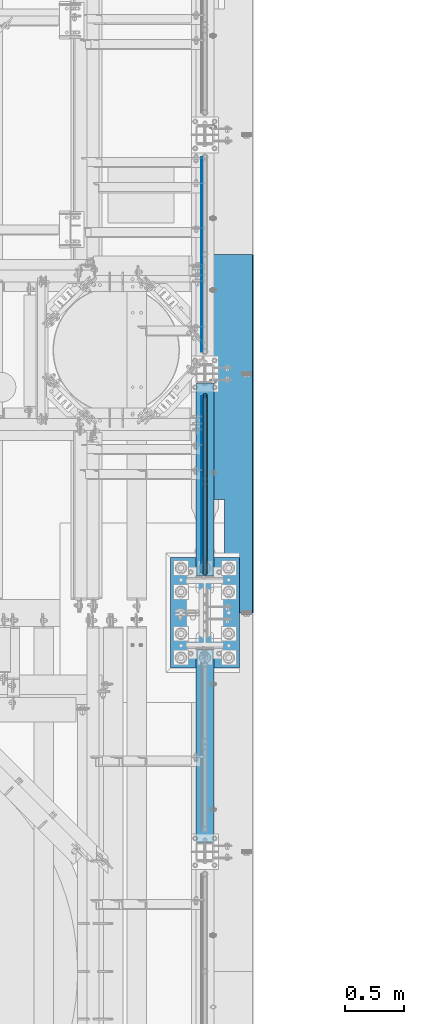
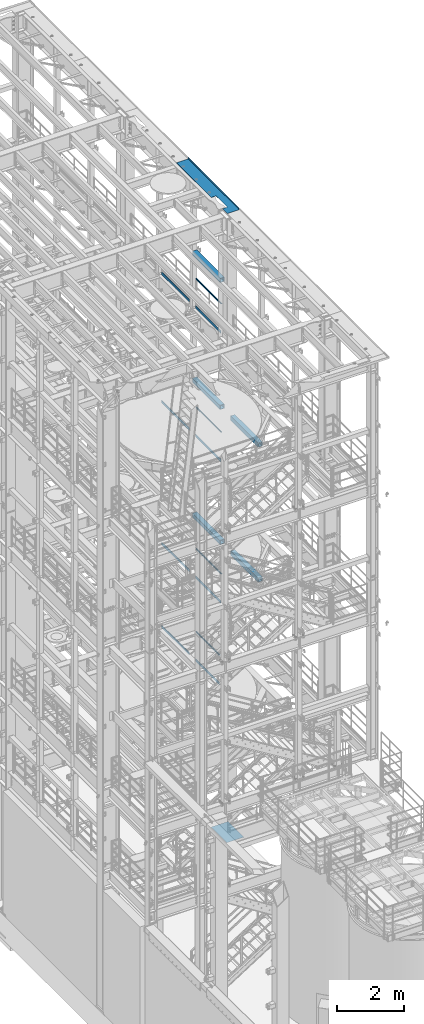
# One storey, part 1036 of 1876: 19 beams, 15 elements without a shape of their own.
"""IFC2X3 building model written with IfcOpenShell, lengths in millimetres."""

import ifcopenshell
import ifcopenshell.guid

model = None  # the IFC model being written
_history = None  # IfcOwnerHistory: only IFC2X3 demands one
_inside = {}  # id of a spatial element -> (the spatial element, [elements in it])
_under = {}  # id of a project, library or spatial element -> (it, [spatial elements below it])
_declared = {}  # id of a project -> (the project, [libraries it declares])
_typed = {}  # id of a type object -> (the type object, [elements of that type])
_made_of = {}  # id of a material, layer set ... -> (it, [elements and type objects made of it])


def new_model(schema):
    """Start an empty IFC model of exactly this schema.

    Asked for "IFC4X3", IfcOpenShell would pick the latest addendum, in which some entities
    have other attributes; the version numbers below select the first issue.
    IFC2X3 requires an IfcOwnerHistory on every rooted entity: one is made here for all.
    """
    global model, _history
    if schema == "IFC4X3":
        model = ifcopenshell.file(schema_version=(4, 3, 0, 0))
    else:
        model = ifcopenshell.file(schema=schema)
    _inside.clear()
    _under.clear()
    _declared.clear()
    _typed.clear()
    _made_of.clear()
    _history = None
    if model.schema == "IFC2X3":
        org = make("IfcOrganization", Name="unknown")
        user = make(
            "IfcPersonAndOrganization",
            ThePerson=make("IfcPerson", FamilyName="unknown"),
            TheOrganization=org,
        )
        app = make(
            "IfcApplication",
            ApplicationDeveloper=org,
            Version="unknown",
            ApplicationFullName="unknown",
            ApplicationIdentifier="unknown",
        )
        _history = make(
            "IfcOwnerHistory",
            OwningUser=user,
            OwningApplication=app,
            ChangeAction="ADDED",
            CreationDate=0,
        )
    return model


def make(cls, **values):
    """One entity of the class cls with the attributes given. An attribute that is None is left unset."""
    return model.create_entity(
        cls, **{name: value for name, value in values.items() if value is not None}
    )


def rooted(cls, **values):
    """An entity with a GlobalId (a new one), such as an element, a storey or a relation."""
    return make(cls, GlobalId=ifcopenshell.guid.new(), OwnerHistory=_history, **values)


def si_unit(unit_type, name, prefix=None):
    """IfcSIUnit, for example si_unit("LENGTHUNIT", "METRE", prefix="MILLI")."""
    return make("IfcSIUnit", UnitType=unit_type, Prefix=prefix, Name=name)


def assignment(units):
    """IfcUnitAssignment: the units of a project."""
    return None if units is None else make("IfcUnitAssignment", Units=units)


def point(xyz):
    """IfcCartesianPoint."""
    return None if xyz is None else make("IfcCartesianPoint", Coordinates=xyz)


def direction(xyz):
    """IfcDirection."""
    return None if xyz is None else make("IfcDirection", DirectionRatios=xyz)


def frame(location, z_axis=None, x_axis=None):
    """IfcAxis2Placement3D, a coordinate frame: its origin and axes. An axis left out is left unset."""
    return make(
        "IfcAxis2Placement3D",
        Location=point(location),
        Axis=direction(z_axis),
        RefDirection=direction(x_axis),
    )


def origin_with_axes():
    """The frame at (0, 0, 0) with the z axis (0, 0, 1) and the x axis (1, 0, 0) written out."""
    return frame((0.0, 0.0, 0.0), z_axis=(0.0, 0.0, 1.0), x_axis=(1.0, 0.0, 0.0))


def place(relative_to, where):
    """IfcLocalPlacement: puts the frame where relative to a parent placement (None: the world)."""
    return make(
        "IfcLocalPlacement", PlacementRelTo=relative_to, RelativePlacement=where
    )


def context(
    kind, dimensions, precision=None, world=None, true_north=None, identifier=None
):
    """IfcGeometricRepresentationContext, for example the 3D "Model" context."""
    return make(
        "IfcGeometricRepresentationContext",
        ContextIdentifier=identifier,
        ContextType=kind,
        CoordinateSpaceDimension=dimensions,
        Precision=precision,
        WorldCoordinateSystem=world,
        TrueNorth=true_north,
    )


def subcontext(parent, identifier, kind, view, scale=None):
    """IfcGeometricRepresentationSubContext, for example "Body" below "Model"."""
    return make(
        "IfcGeometricRepresentationSubContext",
        ContextIdentifier=identifier,
        ContextType=kind,
        ParentContext=parent,
        TargetScale=scale,
        TargetView=view,
    )


def project(units=None, contexts=None):
    """IfcProject with its units and contexts."""
    return rooted(
        "IfcProject",
        Name="project",
        RepresentationContexts=contexts,
        UnitsInContext=assignment(units),
    )


def spatial(cls, under=None, at=None, **own):
    """A site, building, storey or space (cls), placed at a placement, below another one or the project."""
    s = rooted(cls, ObjectPlacement=at, **own)
    if under is not None:
        _under.setdefault(under.id(), (under, []))[1].append(s)
    return s


def faces_of(points, faces, orient=None, outer=None):
    """IfcFace entities. A face is a list of loops; a loop is a list of indices into points, from 0.

    orient and outer hold one flag for each loop. By default every Orientation is true, the
    first loop of a face is its IfcFaceOuterBound and the others are IfcFaceBound.
    """
    made = []
    for i, loops in enumerate(faces):
        bounds = []
        for j, loop in enumerate(loops):
            is_outer = j == 0 if outer is None else outer[i][j]
            bounds.append(
                make(
                    "IfcFaceOuterBound" if is_outer else "IfcFaceBound",
                    Bound=make("IfcPolyLoop", Polygon=[points[k] for k in loop]),
                    Orientation=True if orient is None else orient[i][j],
                )
            )
        made.append(make("IfcFace", Bounds=bounds))
    return made


def faceted_brep(points, faces, orient=None, outer=None, voids=None):
    """IfcFacetedBrep: a solid bounded by flat faces; with voids (closed shells), ...WithVoids."""
    shared = [point(p) for p in points]
    hull = make("IfcClosedShell", CfsFaces=faces_of(shared, faces, orient, outer))
    if voids is None:
        return make("IfcFacetedBrep", Outer=hull)
    return make(
        "IfcFacetedBrepWithVoids",
        Outer=hull,
        Voids=[
            make(cls, CfsFaces=faces_of(shared, fs, o, b)) for cls, fs, o, b in voids
        ],
    )


def shape(context_of_items, identifier, shape_type, items):
    """IfcShapeRepresentation: the items that make up one representation, for example the "Body"."""
    return make(
        "IfcShapeRepresentation",
        ContextOfItems=context_of_items,
        RepresentationIdentifier=identifier,
        RepresentationType=shape_type,
        Items=items,
    )


def material(Name=None, Category=None):
    """IfcMaterial."""
    return make("IfcMaterial", Name=Name, Category=Category)


def made_of(thing, what):
    """Note that an element or type object is made of a material, layer set ...; save() writes the relation."""
    if what is not None:
        _made_of.setdefault(what.id(), (what, []))[1].append(thing)
    return thing


def type_object(cls, material=None, **own):
    """A type object (cls), such as IfcWallType, which elements share."""
    return made_of(rooted(cls, **own), material)


def element(
    cls,
    number,
    at=None,
    inside=None,
    cuts=None,
    type_object=None,
    material=None,
    context=None,
    identifier="Body",
    shape_type=None,
    held_by="IfcProductDefinitionShape",
    body=None,
    shapes=None,
    **own,
):
    """One element of the class cls, such as IfcWall. Its Tag is "e" and its number.

    at: its placement. inside: the storey or other place that contains it. cuts: it is an
    opening in that element (IfcRelVoidsElement). A single representation is given by context,
    identifier, shape_type and body (its items); several are given by shapes. held_by: the class
    of the entity that holds the representations. save() writes the other relations.
    """
    e = rooted(cls, Tag="e%d" % number, ObjectPlacement=at, **own)
    if body is not None:
        shapes = [shape(context, identifier, shape_type, body)]
    if shapes is not None:
        e.Representation = make(held_by, Representations=shapes)
    if inside is not None:
        _inside.setdefault(inside.id(), (inside, []))[1].append(e)
    if cuts is not None:
        rooted(
            "IfcRelVoidsElement", RelatingBuildingElement=cuts, RelatedOpeningElement=e
        )
    if type_object is not None:
        _typed.setdefault(type_object.id(), (type_object, []))[1].append(e)
    return made_of(e, material)


def aggregate(whole, parts):
    """IfcRelAggregates: a whole, such as a stair, and the parts it consists of."""
    return rooted("IfcRelAggregates", RelatingObject=whole, RelatedObjects=parts)


def save(model, path):
    """Write the relations noted so far, then the file.

    IfcRelAggregates (storeys below a building ...), IfcRelContainedInSpatialStructure (elements
    in a storey), IfcRelDefinesByType, IfcRelAssociatesMaterial and IfcRelDeclares: one each for
    every whole, place, type object, material and project.
    """
    for whole, parts in _under.values():
        aggregate(whole, parts)
    for where, things in _inside.values():
        rooted(
            "IfcRelContainedInSpatialStructure",
            RelatedElements=things,
            RelatingStructure=where,
        )
    for kind, things in _typed.values():
        rooted("IfcRelDefinesByType", RelatedObjects=things, RelatingType=kind)
    for what, things in _made_of.values():
        rooted("IfcRelAssociatesMaterial", RelatedObjects=things, RelatingMaterial=what)
    for by, libraries in _declared.values():
        rooted("IfcRelDeclares", RelatingContext=by, RelatedDefinitions=libraries)
    model.write(path)


model = new_model("IFC2X3")

# Units and contexts
model_context = context("Model", 3, precision=1e-05, world=origin_with_axes())
body_context = subcontext(model_context, "Body", "Model", "MODEL_VIEW")
ifc_project = project(units=[si_unit("LENGTHUNIT", "METRE", prefix="MILLI"), si_unit("AREAUNIT", "SQUARE_METRE"), si_unit("VOLUMEUNIT", "CUBIC_METRE"), si_unit("MASSUNIT", "GRAM", prefix="KILO"), si_unit("TIMEUNIT", "SECOND"), si_unit("PLANEANGLEUNIT", "RADIAN"), si_unit("SOLIDANGLEUNIT", "STERADIAN"), si_unit("THERMODYNAMICTEMPERATUREUNIT", "DEGREE_CELSIUS"), si_unit("LUMINOUSINTENSITYUNIT", "LUMEN")], contexts=[model_context])

# Site, building, storey
site_placement = place(None, origin_with_axes())
site = spatial("IfcSite", under=ifc_project, at=site_placement, CompositionType="ELEMENT")
building_placement = place(site_placement, origin_with_axes())
building = spatial("IfcBuilding", under=site, at=building_placement, Name="Undefined", CompositionType="ELEMENT")
storey_placement = place(building_placement, origin_with_axes())
storey = spatial("IfcBuildingStorey", under=building, at=storey_placement, Name="Undefined", CompositionType="ELEMENT", Elevation=0.0)

# Assembly, beam
assembly_1_placement = place(storey_placement, origin_with_axes())
assembly_1 = element("IfcElementAssembly", 1, at=assembly_1_placement, inside=storey, Name="RAIL", AssemblyPlace="NOTDEFINED", PredefinedType="RIGID_FRAME")
ifc_material_1 = material()
beam_type_1 = type_object("IfcBeamType", Name="PIPE1-1/2SCH40", PredefinedType="NOTDEFINED")
beam_1_placement = place(assembly_1_placement, frame((7620.0, 1844.675, 19059.525), z_axis=(0.0, 0.0, -1.0), x_axis=(0.0, 1.0, 0.0)))
beam_1 = element("IfcBeam", 2, at=beam_1_placement, type_object=beam_type_1, material=ifc_material_1, Name="RAIL", ObjectType="PIPE1-1/2SCH40", context=body_context, shape_type="Brep", body=[
    faceted_brep([(24.1300000000001, -20.4469999999999, 0.0), (34.3535000000002, -17.7076214311803, 10.2235000000001), (1511.8715, -17.7076214311801, 10.2235000000001), (1522.095, -20.4470000000001, 0.0), (41.8376214311802, -10.2235000000001, 17.7076214311819), (1504.38737856882, -10.2235000000001, 17.7076214311819), (44.5770000000002, 0.0, 20.4470000000001), (1501.648, 0.0, 20.4470000000001), (41.8376214311802, 10.2235000000001, 17.7076214311819), (1504.38737856882, 10.2235000000001, 17.7076214311819), (34.3535000000002, 17.7076214311803, 10.2235000000001), (1511.8715, 17.7076214311801, 10.2235000000001), (24.1300000000001, 20.4469999999999, 0.0), (1522.095, 20.4470000000001, 0.0), (13.9065000000001, 17.7076214311803, -10.2235000000001), (1532.3185, 17.7076214311801, -10.2235000000001), (6.42237856882002, 10.2235000000001, -17.7076214311819), (1539.80262143118, 10.2235000000001, -17.7076214311819), (3.68299999999999, 0.0, -20.4470000000001), (1542.542, 0.0, -20.4470000000001), (6.42237856882002, -10.2235000000001, -17.7076214311819), (1539.80262143118, -10.2235000000001, -17.7076214311819), (13.9065000000001, -17.7076214311803, -10.2235000000001), (1532.3185, -17.7076214311801, -10.2235000000001), (24.1299999999854, -24.1299999999992, 0.0), (12.0650000000064, -20.8971929933177, -12.0649999999987), (1534.16, -20.8971929933186, -12.0649999999987), (1522.095, -24.1300000000001, 0.0), (3.23280700668147, -12.0650000000001, -20.8971929933177), (1542.99219299332, -12.0649999999996, -20.8971929933177), (-1.45519152283669e-11, 0.0, -24.130000000001), (1546.225, 0.0, -24.130000000001), (3.23280700668147, 12.0650000000001, -20.8971929933177), (1542.99219299332, 12.0649999999996, -20.8971929933177), (12.0650000000064, 20.8971929933177, -12.0649999999987), (1534.16, 20.8971929933186, -12.0649999999987), (24.1300000000047, 24.1299999999992, 0.0), (1522.095, 24.1300000000001, 0.0), (36.1949999999997, 20.8971929933184, 12.0649999999987), (1510.03, 20.8971929933186, 12.0649999999987), (45.0271929933187, 12.0650000000001, 20.8971929933177), (1501.19780700668, 12.0649999999996, 20.8971929933177), (48.2600000000002, 0.0, 24.130000000001), (1497.965, 0.0, 24.130000000001), (45.0271929933187, -12.0650000000001, 20.8971929933177), (1501.19780700668, -12.0649999999996, 20.8971929933177), (36.1949999999997, -20.8971929933184, 12.0649999999987), (1510.03, -20.8971929933186, 12.0649999999987)], [[[0, 1, 2, 3]], [[1, 4, 5, 2]], [[4, 6, 7, 5]], [[6, 8, 9, 7]], [[8, 10, 11, 9]], [[10, 12, 13, 11]], [[12, 14, 15, 13]], [[14, 16, 17, 15]], [[16, 18, 19, 17]], [[18, 20, 21, 19]], [[20, 22, 23, 21]], [[22, 0, 3, 23]], [[24, 25, 26, 27]], [[25, 28, 29, 26]], [[28, 30, 31, 29]], [[30, 32, 33, 31]], [[32, 34, 35, 33]], [[34, 36, 37, 35]], [[36, 38, 39, 37]], [[38, 40, 41, 39]], [[40, 42, 43, 41]], [[42, 44, 45, 43]], [[44, 46, 47, 45]], [[46, 24, 27, 47]], [[29, 31, 33, 35, 37, 39, 41, 43, 45, 47, 27, 26], [5, 7, 9, 11, 13, 15, 17, 19, 21, 23, 3, 2]], [[46, 44, 42, 40, 38, 36, 34, 32, 30, 28, 25, 24], [22, 20, 18, 16, 14, 12, 10, 8, 6, 4, 1, 0]]]),
])

assembly_2_placement = place(storey_placement, origin_with_axes())
assembly_2 = element("IfcElementAssembly", 3, at=assembly_2_placement, inside=storey, Name="RAIL", AssemblyPlace="NOTDEFINED", PredefinedType="RIGID_FRAME")
beam_2_placement = place(assembly_2_placement, frame((7620.0, 1844.675, 14385.925), z_axis=(0.0, 0.0, -1.0), x_axis=(0.0, 1.0, 0.0)))
beam_2 = element("IfcBeam", 4, at=beam_2_placement, type_object=beam_type_1, material=ifc_material_1, Name="RAIL", ObjectType="PIPE1-1/2SCH40", context=body_context, shape_type="Brep", body=[
    faceted_brep([(24.1300000000001, -20.4469999999999, 0.0), (34.3535000000002, -17.7076214311803, 10.2235000000001), (1511.8715, -17.7076214311801, 10.2235000000001), (1522.095, -20.4470000000001, 0.0), (41.8376214311802, -10.2235000000001, 17.7076214311819), (1504.38737856882, -10.2235000000001, 17.7076214311819), (44.5770000000002, 0.0, 20.4470000000001), (1501.648, 0.0, 20.4470000000001), (41.8376214311802, 10.2235000000001, 17.7076214311819), (1504.38737856882, 10.2235000000001, 17.7076214311819), (34.3535000000002, 17.7076214311803, 10.2235000000001), (1511.8715, 17.7076214311801, 10.2235000000001), (24.1300000000001, 20.4469999999999, 0.0), (1522.095, 20.4470000000001, 0.0), (13.9065000000001, 17.7076214311803, -10.2235000000001), (1532.3185, 17.7076214311801, -10.2235000000001), (6.42237856882002, 10.2235000000001, -17.7076214311819), (1539.80262143118, 10.2235000000001, -17.7076214311819), (3.68299999999999, 0.0, -20.4470000000001), (1542.542, 0.0, -20.4470000000001), (6.42237856882002, -10.2235000000001, -17.7076214311819), (1539.80262143118, -10.2235000000001, -17.7076214311819), (13.9065000000001, -17.7076214311803, -10.2235000000001), (1532.3185, -17.7076214311801, -10.2235000000001), (24.1299999999854, -24.1299999999992, 0.0), (12.0650000000064, -20.8971929933177, -12.0649999999987), (1534.16, -20.8971929933186, -12.0649999999987), (1522.095, -24.1300000000001, 0.0), (3.23280700668147, -12.0650000000001, -20.8971929933177), (1542.99219299332, -12.0649999999996, -20.8971929933177), (-1.45519152283669e-11, 0.0, -24.130000000001), (1546.225, 0.0, -24.130000000001), (3.23280700668147, 12.0650000000001, -20.8971929933177), (1542.99219299332, 12.0649999999996, -20.8971929933177), (12.0650000000064, 20.8971929933177, -12.0649999999987), (1534.16, 20.8971929933186, -12.0649999999987), (24.1300000000047, 24.1299999999992, 0.0), (1522.095, 24.1300000000001, 0.0), (36.1949999999997, 20.8971929933184, 12.0649999999987), (1510.03, 20.8971929933186, 12.0649999999987), (45.0271929933187, 12.0650000000001, 20.8971929933177), (1501.19780700668, 12.0649999999996, 20.8971929933177), (48.2600000000002, 0.0, 24.130000000001), (1497.965, 0.0, 24.130000000001), (45.0271929933187, -12.0650000000001, 20.8971929933177), (1501.19780700668, -12.0649999999996, 20.8971929933177), (36.1949999999997, -20.8971929933184, 12.0649999999987), (1510.03, -20.8971929933186, 12.0649999999987)], [[[0, 1, 2, 3]], [[1, 4, 5, 2]], [[4, 6, 7, 5]], [[6, 8, 9, 7]], [[8, 10, 11, 9]], [[10, 12, 13, 11]], [[12, 14, 15, 13]], [[14, 16, 17, 15]], [[16, 18, 19, 17]], [[18, 20, 21, 19]], [[20, 22, 23, 21]], [[22, 0, 3, 23]], [[24, 25, 26, 27]], [[25, 28, 29, 26]], [[28, 30, 31, 29]], [[30, 32, 33, 31]], [[32, 34, 35, 33]], [[34, 36, 37, 35]], [[36, 38, 39, 37]], [[38, 40, 41, 39]], [[40, 42, 43, 41]], [[42, 44, 45, 43]], [[44, 46, 47, 45]], [[46, 24, 27, 47]], [[29, 31, 33, 35, 37, 39, 41, 43, 45, 47, 27, 26], [5, 7, 9, 11, 13, 15, 17, 19, 21, 23, 3, 2]], [[46, 44, 42, 40, 38, 36, 34, 32, 30, 28, 25, 24], [22, 20, 18, 16, 14, 12, 10, 8, 6, 4, 1, 0]]]),
])

assembly_3_placement = place(storey_placement, origin_with_axes())
assembly_3 = element("IfcElementAssembly", 5, at=assembly_3_placement, inside=storey, Name="RAIL", AssemblyPlace="NOTDEFINED", PredefinedType="RIGID_FRAME")
beam_3_placement = place(assembly_3_placement, frame((7620.0, 1844.675, 9229.725), z_axis=(0.0, 0.0, -1.0), x_axis=(0.0, 1.0, 0.0)))
beam_3 = element("IfcBeam", 6, at=beam_3_placement, type_object=beam_type_1, material=ifc_material_1, Name="RAIL", ObjectType="PIPE1-1/2SCH40", context=body_context, shape_type="Brep", body=[
    faceted_brep([(24.1300000000001, -20.4469999999999, 0.0), (34.3535000000002, -17.7076214311803, 10.2235000000001), (1511.8715, -17.7076214311801, 10.2235000000001), (1522.095, -20.4470000000001, 0.0), (41.8376214311802, -10.2235000000001, 17.7076214311819), (1504.38737856882, -10.2235000000001, 17.7076214311819), (44.5770000000002, 0.0, 20.4470000000001), (1501.648, 0.0, 20.4470000000001), (41.8376214311802, 10.2235000000001, 17.7076214311819), (1504.38737856882, 10.2235000000001, 17.7076214311819), (34.3535000000002, 17.7076214311803, 10.2235000000001), (1511.8715, 17.7076214311801, 10.2235000000001), (24.1300000000001, 20.4469999999999, 0.0), (1522.095, 20.4470000000001, 0.0), (13.9065000000001, 17.7076214311803, -10.2235000000001), (1532.3185, 17.7076214311801, -10.2235000000001), (6.42237856882002, 10.2235000000001, -17.7076214311819), (1539.80262143118, 10.2235000000001, -17.7076214311819), (3.68299999999999, 0.0, -20.4470000000001), (1542.542, 0.0, -20.4470000000001), (6.42237856882002, -10.2235000000001, -17.7076214311819), (1539.80262143118, -10.2235000000001, -17.7076214311819), (13.9065000000001, -17.7076214311803, -10.2235000000001), (1532.3185, -17.7076214311801, -10.2235000000001), (24.1299999999854, -24.1299999999992, 0.0), (12.0650000000064, -20.8971929933177, -12.0649999999987), (1534.16, -20.8971929933186, -12.0649999999987), (1522.095, -24.1300000000001, 0.0), (3.23280700668147, -12.0650000000001, -20.8971929933177), (1542.99219299332, -12.0649999999996, -20.8971929933177), (-1.45519152283669e-11, 0.0, -24.130000000001), (1546.225, 0.0, -24.130000000001), (3.23280700668147, 12.0650000000001, -20.8971929933177), (1542.99219299332, 12.0649999999996, -20.8971929933177), (12.0650000000064, 20.8971929933177, -12.0649999999987), (1534.16, 20.8971929933186, -12.0649999999987), (24.1300000000047, 24.1299999999992, 0.0), (1522.095, 24.1300000000001, 0.0), (36.1949999999997, 20.8971929933184, 12.0649999999987), (1510.03, 20.8971929933186, 12.0649999999987), (45.0271929933187, 12.0650000000001, 20.8971929933177), (1501.19780700668, 12.0649999999996, 20.8971929933177), (48.2600000000002, 0.0, 24.130000000001), (1497.965, 0.0, 24.130000000001), (45.0271929933187, -12.0650000000001, 20.8971929933177), (1501.19780700668, -12.0649999999996, 20.8971929933177), (36.1949999999997, -20.8971929933184, 12.0649999999987), (1510.03, -20.8971929933186, 12.0649999999987)], [[[0, 1, 2, 3]], [[1, 4, 5, 2]], [[4, 6, 7, 5]], [[6, 8, 9, 7]], [[8, 10, 11, 9]], [[10, 12, 13, 11]], [[12, 14, 15, 13]], [[14, 16, 17, 15]], [[16, 18, 19, 17]], [[18, 20, 21, 19]], [[20, 22, 23, 21]], [[22, 0, 3, 23]], [[24, 25, 26, 27]], [[25, 28, 29, 26]], [[28, 30, 31, 29]], [[30, 32, 33, 31]], [[32, 34, 35, 33]], [[34, 36, 37, 35]], [[36, 38, 39, 37]], [[38, 40, 41, 39]], [[40, 42, 43, 41]], [[42, 44, 45, 43]], [[44, 46, 47, 45]], [[46, 24, 27, 47]], [[29, 31, 33, 35, 37, 39, 41, 43, 45, 47, 27, 26], [5, 7, 9, 11, 13, 15, 17, 19, 21, 23, 3, 2]], [[46, 44, 42, 40, 38, 36, 34, 32, 30, 28, 25, 24], [22, 20, 18, 16, 14, 12, 10, 8, 6, 4, 1, 0]]]),
])

assembly_4_placement = place(storey_placement, origin_with_axes())
assembly_4 = element("IfcElementAssembly", 7, at=assembly_4_placement, inside=storey, Name="RAIL", AssemblyPlace="NOTDEFINED", PredefinedType="RIGID_FRAME")
beam_4_placement = place(assembly_4_placement, frame((7620.0, 1939.925, 6207.125), z_axis=(0.0, 0.0, -1.0), x_axis=(0.0, 1.0, 0.0)))
beam_4 = element("IfcBeam", 8, at=beam_4_placement, type_object=beam_type_1, material=ifc_material_1, Name="RAIL", ObjectType="PIPE1-1/2SCH40", context=body_context, shape_type="Brep", body=[
    faceted_brep([(24.1300000000001, -20.4469999999999, 0.0), (34.3535000000002, -17.7076214311803, 10.2235000000001), (1416.6215, -17.7076214311801, 10.2235000000001), (1426.845, -20.4470000000001, 0.0), (41.8376214311802, -10.2235000000001, 17.7076214311819), (1409.13737856882, -10.2235000000001, 17.7076214311801), (44.5770000000002, 0.0, 20.4470000000001), (1406.398, 0.0, 20.4470000000001), (41.8376214311802, 10.2235000000001, 17.7076214311819), (1409.13737856882, 10.2235000000001, 17.7076214311801), (34.3535000000002, 17.7076214311803, 10.2235000000001), (1416.6215, 17.7076214311801, 10.2235000000001), (24.1300000000001, 20.4469999999999, 0.0), (1426.845, 20.4470000000001, 0.0), (13.9065000000001, 17.7076214311803, -10.2235000000001), (1437.0685, 17.7076214311801, -10.2235000000001), (6.42237856882002, 10.2235000000001, -17.7076214311819), (1444.55262143118, 10.2235000000001, -17.7076214311801), (3.68299999999999, 0.0, -20.4470000000001), (1447.292, 0.0, -20.4470000000001), (6.42237856882002, -10.2235000000001, -17.7076214311819), (1444.55262143118, -10.2235000000001, -17.7076214311801), (13.9065000000001, -17.7076214311803, -10.2235000000001), (1437.0685, -17.7076214311801, -10.2235000000001), (24.1299999999854, -24.1299999999992, 0.0), (12.0650000000064, -20.8971929933177, -12.0649999999987), (1438.91, -20.8971929933186, -12.0649999999996), (1426.845, -24.1300000000001, 0.0), (3.23280700668147, -12.0650000000001, -20.8971929933177), (1447.74219299332, -12.0649999999996, -20.8971929933186), (-1.45519152283669e-11, 0.0, -24.130000000001), (1450.975, 0.0, -24.1300000000001), (3.23280700668147, 12.0650000000001, -20.8971929933177), (1447.74219299332, 12.0649999999996, -20.8971929933186), (12.0650000000064, 20.8971929933177, -12.0649999999987), (1438.91, 20.8971929933186, -12.0649999999996), (24.1300000000047, 24.1299999999992, 0.0), (1426.845, 24.1300000000001, 0.0), (36.1949999999997, 20.8971929933184, 12.0649999999987), (1414.78, 20.8971929933186, 12.0649999999996), (45.0271929933187, 12.0650000000001, 20.8971929933177), (1405.94780700668, 12.0649999999996, 20.8971929933186), (48.2600000000002, 0.0, 24.130000000001), (1402.715, 0.0, 24.1300000000001), (45.0271929933187, -12.0650000000001, 20.8971929933177), (1405.94780700668, -12.0649999999996, 20.8971929933186), (36.1949999999997, -20.8971929933184, 12.0649999999987), (1414.78, -20.8971929933186, 12.0649999999996)], [[[0, 1, 2, 3]], [[1, 4, 5, 2]], [[4, 6, 7, 5]], [[6, 8, 9, 7]], [[8, 10, 11, 9]], [[10, 12, 13, 11]], [[12, 14, 15, 13]], [[14, 16, 17, 15]], [[16, 18, 19, 17]], [[18, 20, 21, 19]], [[20, 22, 23, 21]], [[22, 0, 3, 23]], [[24, 25, 26, 27]], [[25, 28, 29, 26]], [[28, 30, 31, 29]], [[30, 32, 33, 31]], [[32, 34, 35, 33]], [[34, 36, 37, 35]], [[36, 38, 39, 37]], [[38, 40, 41, 39]], [[40, 42, 43, 41]], [[42, 44, 45, 43]], [[44, 46, 47, 45]], [[46, 24, 27, 47]], [[29, 31, 33, 35, 37, 39, 41, 43, 45, 47, 27, 26], [5, 7, 9, 11, 13, 15, 17, 19, 21, 23, 3, 2]], [[46, 44, 42, 40, 38, 36, 34, 32, 30, 28, 25, 24], [22, 20, 18, 16, 14, 12, 10, 8, 6, 4, 1, 0]]]),
])

assembly_5_placement = place(storey_placement, origin_with_axes())
assembly_5 = element("IfcElementAssembly", 9, at=assembly_5_placement, inside=storey, Name="BEAM", AssemblyPlace="NOTDEFINED", PredefinedType="RIGID_FRAME")
ifc_material_2 = material()
beam_type_2 = type_object("IfcBeamType", Name="HSS6X6X3/8", PredefinedType="NOTDEFINED")
beam_5_placement = place(assembly_5_placement, frame((7620.0, 1812.925, 19958.05), z_axis=(-1.0, 0.0, 0.0), x_axis=(0.0, 1.0, 0.0)))
beam_5 = element("IfcBeam", 10, at=beam_5_placement, type_object=beam_type_2, material=ifc_material_2, Name="BEAM", ObjectType="HSS6X6X3/8", context=body_context, shape_type="Brep", body=[
    faceted_brep([(22.2249999999995, 66.6749999999993, -66.675), (22.2249999999995, -66.6749999999993, -66.675), (1666.875, -66.6749999999993, -66.675), (1666.875, 66.6749999999993, -66.675), (22.2249999999995, -66.6749999999993, 66.675), (1666.875, -66.6749999999993, 66.675), (22.2249999999995, 66.6749999999993, 66.675), (1666.875, 66.6749999999993, 66.675), (22.2249999999995, 76.2000000000007, -76.2), (22.2249999999995, 76.2000000000007, 76.2), (1666.875, 76.2000000000007, 76.2), (1666.875, 76.2000000000007, -76.2), (22.2249999999995, -76.2000000000007, 76.2), (1666.875, -76.2000000000007, 76.2), (22.2249999999995, -76.2000000000007, -76.2), (1666.875, -76.2000000000007, -76.2)], [[[0, 1, 2, 3]], [[1, 4, 5, 2]], [[4, 6, 7, 5]], [[6, 0, 3, 7]], [[8, 9, 10, 11]], [[9, 12, 13, 10]], [[12, 14, 15, 13]], [[14, 8, 11, 15]], [[13, 15, 11, 10], [5, 7, 3, 2]], [[14, 12, 9, 8], [6, 4, 1, 0]]]),
])
aggregate(assembly_5, [beam_5])

assembly_6_placement = place(storey_placement, origin_with_axes())
assembly_6 = element("IfcElementAssembly", 11, at=assembly_6_placement, inside=storey, Name="BEAM", AssemblyPlace="NOTDEFINED", PredefinedType="RIGID_FRAME")
beam_6_placement = place(assembly_6_placement, frame((7620.0, 1812.925, 15335.25), z_axis=(-1.0, 0.0, 0.0), x_axis=(0.0, 1.0, 0.0)))
beam_6 = element("IfcBeam", 12, at=beam_6_placement, type_object=beam_type_2, material=ifc_material_2, Name="BEAM", ObjectType="HSS6X6X3/8", context=body_context, shape_type="Brep", body=[
    faceted_brep([(22.2249999999995, 66.6749999999993, -66.675), (22.2249999999995, -66.6749999999993, -66.675), (1666.875, -66.6749999999993, -66.675), (1666.875, 66.6749999999993, -66.675), (22.2249999999995, -66.6749999999993, 66.675), (1666.875, -66.6749999999993, 66.675), (22.2249999999995, 66.6749999999993, 66.675), (1666.875, 66.6749999999993, 66.675), (22.2249999999995, 76.2000000000007, -76.2), (22.2249999999995, 76.2000000000007, 76.2), (1666.875, 76.2000000000007, 76.2), (1666.875, 76.2000000000007, -76.2), (22.2249999999995, -76.2000000000007, 76.2), (1666.875, -76.2000000000007, 76.2), (22.2249999999995, -76.2000000000007, -76.2), (1666.875, -76.2000000000007, -76.2)], [[[0, 1, 2, 3]], [[1, 4, 5, 2]], [[4, 6, 7, 5]], [[6, 0, 3, 7]], [[8, 9, 10, 11]], [[9, 12, 13, 10]], [[12, 14, 15, 13]], [[14, 8, 11, 15]], [[13, 15, 11, 10], [5, 7, 3, 2]], [[14, 12, 9, 8], [6, 4, 1, 0]]]),
])
aggregate(assembly_6, [beam_6])

assembly_7_placement = place(storey_placement, origin_with_axes())
assembly_7 = element("IfcElementAssembly", 13, at=assembly_7_placement, inside=storey, Name="BEAM", AssemblyPlace="NOTDEFINED", PredefinedType="RIGID_FRAME")
beam_7_placement = place(assembly_7_placement, frame((7620.0, -508.0, 15335.25), z_axis=(-1.0, 0.0, 0.0), x_axis=(0.0, 1.0, 0.0)))
beam_7 = element("IfcBeam", 14, at=beam_7_placement, type_object=beam_type_2, material=ifc_material_2, Name="BEAM", ObjectType="HSS6X6X3/8", context=body_context, shape_type="Brep", body=[
    faceted_brep([(76.2000000000007, 66.6749999999993, -66.6750000000002), (76.2000000000007, -66.6749999999993, -66.6750000000002), (1720.85, -66.6749999999993, -66.675), (1720.85, 66.6749999999993, -66.675), (76.2000000000007, -66.6749999999993, 66.6750000000002), (1720.85, -66.6749999999993, 66.675), (76.2000000000007, 66.6749999999993, 66.6750000000002), (1720.85, 66.6749999999993, 66.675), (76.2000000000007, 76.2000000000007, -76.1999999999998), (76.2000000000007, 76.2000000000007, 76.1999999999998), (1720.85, 76.2000000000007, 76.2), (1720.85, 76.2000000000007, -76.2), (76.2000000000007, -76.2000000000007, 76.1999999999998), (1720.85, -76.2000000000007, 76.2), (76.2000000000007, -76.2000000000007, -76.1999999999998), (1720.85, -76.2000000000007, -76.2)], [[[0, 1, 2, 3]], [[1, 4, 5, 2]], [[4, 6, 7, 5]], [[6, 0, 3, 7]], [[8, 9, 10, 11]], [[9, 12, 13, 10]], [[12, 14, 15, 13]], [[14, 8, 11, 15]], [[13, 15, 11, 10], [5, 7, 3, 2]], [[14, 12, 9, 8], [6, 4, 1, 0]]]),
])
aggregate(assembly_7, [beam_7])

assembly_8_placement = place(storey_placement, origin_with_axes())
assembly_8 = element("IfcElementAssembly", 15, at=assembly_8_placement, inside=storey, Name="BEAM", AssemblyPlace="NOTDEFINED", PredefinedType="RIGID_FRAME")
beam_8_placement = place(assembly_8_placement, frame((7620.0, 1812.925, 10420.35), z_axis=(-1.0, 0.0, 0.0), x_axis=(0.0, 1.0, 0.0)))
beam_8 = element("IfcBeam", 16, at=beam_8_placement, type_object=beam_type_2, material=ifc_material_2, Name="BEAM", ObjectType="HSS6X6X3/8", context=body_context, shape_type="Brep", body=[
    faceted_brep([(22.2249999999995, 66.6749999999993, -66.675), (22.2249999999995, -66.6749999999993, -66.675), (1666.875, -66.6749999999993, -66.675), (1666.875, 66.6749999999993, -66.675), (22.2249999999995, -66.6749999999993, 66.675), (1666.875, -66.6749999999993, 66.675), (22.2249999999995, 66.6749999999993, 66.675), (1666.875, 66.6749999999993, 66.675), (22.2249999999995, 76.2000000000007, -76.2), (22.2249999999995, 76.2000000000007, 76.2), (1666.875, 76.2000000000007, 76.2), (1666.875, 76.2000000000007, -76.2), (22.2249999999995, -76.2000000000007, 76.2), (1666.875, -76.2000000000007, 76.2), (22.2249999999995, -76.2000000000007, -76.2), (1666.875, -76.2000000000007, -76.2)], [[[0, 1, 2, 3]], [[1, 4, 5, 2]], [[4, 6, 7, 5]], [[6, 0, 3, 7]], [[8, 9, 10, 11]], [[9, 12, 13, 10]], [[12, 14, 15, 13]], [[14, 8, 11, 15]], [[13, 15, 11, 10], [5, 7, 3, 2]], [[14, 12, 9, 8], [6, 4, 1, 0]]]),
])
aggregate(assembly_8, [beam_8])

assembly_9_placement = place(storey_placement, origin_with_axes())
assembly_9 = element("IfcElementAssembly", 17, at=assembly_9_placement, inside=storey, Name="BEAM", AssemblyPlace="NOTDEFINED", PredefinedType="RIGID_FRAME")
beam_9_placement = place(assembly_9_placement, frame((7620.0, -508.0, 10420.35), z_axis=(-1.0, 0.0, 0.0), x_axis=(0.0, 1.0, 0.0)))
beam_9 = element("IfcBeam", 18, at=beam_9_placement, type_object=beam_type_2, material=ifc_material_2, Name="BEAM", ObjectType="HSS6X6X3/8", context=body_context, shape_type="Brep", body=[
    faceted_brep([(76.2000000000007, 66.6749999999993, -66.6750000000002), (76.2000000000007, -66.6749999999993, -66.6750000000002), (1720.85, -66.6749999999993, -66.675), (1720.85, 66.6749999999993, -66.675), (76.2000000000007, -66.6749999999993, 66.6750000000002), (1720.85, -66.6749999999993, 66.675), (76.2000000000007, 66.6749999999993, 66.6750000000002), (1720.85, 66.6749999999993, 66.675), (76.2000000000007, 76.2000000000007, -76.1999999999998), (76.2000000000007, 76.2000000000007, 76.1999999999998), (1720.85, 76.2000000000007, 76.2), (1720.85, 76.2000000000007, -76.2), (76.2000000000007, -76.2000000000007, 76.1999999999998), (1720.85, -76.2000000000007, 76.2), (76.2000000000007, -76.2000000000007, -76.1999999999998), (1720.85, -76.2000000000007, -76.2)], [[[0, 1, 2, 3]], [[1, 4, 5, 2]], [[4, 6, 7, 5]], [[6, 0, 3, 7]], [[8, 9, 10, 11]], [[9, 12, 13, 10]], [[12, 14, 15, 13]], [[14, 8, 11, 15]], [[13, 15, 11, 10], [5, 7, 3, 2]], [[14, 12, 9, 8], [6, 4, 1, 0]]]),
])
aggregate(assembly_9, [beam_9])

assembly_10_placement = place(storey_placement, origin_with_axes())
assembly_10 = element("IfcElementAssembly", 19, at=assembly_10_placement, inside=storey, Name="RAIL", AssemblyPlace="NOTDEFINED", PredefinedType="RIGID_FRAME")
ifc_material_3 = material(Name="STEEL/A36")
beam_type_3 = type_object("IfcBeamType", PredefinedType="NOTDEFINED")
beam_10_placement = place(assembly_10_placement, frame((7592.69500000001, 3745.23, 18049.875), z_axis=(0.0, 0.0, 1.0), x_axis=(0.0, 1.0, 0.0)))
beam_10 = element("IfcBeam", 20, at=beam_10_placement, type_object=beam_type_3, material=ifc_material_3, Name="PLATE", context=body_context, shape_type="Brep", body=[
    faceted_brep([(0.0, 3.17500000000018, -50.8000000000002), (0.0, 3.17500000000018, 50.8000000000002), (1653.54, 3.175, 50.7999999999993), (1653.54, 3.175, -50.7999999999993), (0.0, -3.17500000000018, 50.8000000000002), (1653.54, -3.175, 50.7999999999993), (0.0, -3.17500000000018, -50.8000000000002), (1653.54, -3.175, -50.7999999999993)], [[[0, 1, 2, 3]], [[1, 4, 5, 2]], [[4, 6, 7, 5]], [[6, 0, 3, 7]], [[5, 7, 3, 2]], [[6, 4, 1, 0]]]),
])
aggregate(assembly_10, [beam_10])

# Beam
beam_11_placement = place(assembly_1_placement, frame((7592.69500000001, 1868.805, 18049.875), z_axis=(0.0, 0.0, 1.0), x_axis=(0.0, 1.0, 0.0)))
beam_11 = element("IfcBeam", 21, at=beam_11_placement, type_object=beam_type_3, material=ifc_material_3, Name="PLATE", context=body_context, shape_type="Brep", body=[
    faceted_brep([(0.0, 3.17500000000018, -50.8000000000002), (0.0, 3.17500000000018, 50.8000000000002), (1497.965, 3.175, 50.7999999999993), (1497.965, 3.175, -50.7999999999993), (0.0, -3.17500000000018, 50.8000000000002), (1497.965, -3.175, 50.7999999999993), (0.0, -3.17500000000018, -50.8000000000002), (1497.965, -3.175, -50.7999999999993)], [[[0, 1, 2, 3]], [[1, 4, 5, 2]], [[4, 6, 7, 5]], [[6, 0, 3, 7]], [[5, 7, 3, 2]], [[6, 4, 1, 0]]]),
])

aggregate(assembly_1, [beam_11, beam_1])

# Assembly, beam
assembly_11_placement = place(storey_placement, origin_with_axes())
assembly_11 = element("IfcElementAssembly", 22, at=assembly_11_placement, inside=storey, Name="RAIL", AssemblyPlace="NOTDEFINED", PredefinedType="RIGID_FRAME")
beam_12_placement = place(assembly_11_placement, frame((7592.69500000001, 3745.23, 13376.275), z_axis=(0.0, 0.0, 1.0), x_axis=(0.0, 1.0, 0.0)))
beam_12 = element("IfcBeam", 23, at=beam_12_placement, type_object=beam_type_3, material=ifc_material_3, Name="PLATE", context=body_context, shape_type="Brep", body=[
    faceted_brep([(0.0, 3.17500000000018, -50.8000000000002), (0.0, 3.17500000000018, 50.8000000000002), (1653.54, 3.175, 50.7999999999993), (1653.54, 3.175, -50.7999999999993), (0.0, -3.17500000000018, 50.8000000000002), (1653.54, -3.175, 50.7999999999993), (0.0, -3.17500000000018, -50.8000000000002), (1653.54, -3.175, -50.7999999999993)], [[[0, 1, 2, 3]], [[1, 4, 5, 2]], [[4, 6, 7, 5]], [[6, 0, 3, 7]], [[5, 7, 3, 2]], [[6, 4, 1, 0]]]),
])
aggregate(assembly_11, [beam_12])

# Beam
beam_13_placement = place(assembly_2_placement, frame((7592.69500000001, 1868.805, 13376.275), z_axis=(0.0, 0.0, 1.0), x_axis=(0.0, 1.0, 0.0)))
beam_13 = element("IfcBeam", 24, at=beam_13_placement, type_object=beam_type_3, material=ifc_material_3, Name="PLATE", context=body_context, shape_type="Brep", body=[
    faceted_brep([(0.0, 3.17500000000018, -50.8000000000002), (0.0, 3.17500000000018, 50.8000000000002), (1497.965, 3.175, 50.7999999999993), (1497.965, 3.175, -50.7999999999993), (0.0, -3.17500000000018, 50.8000000000002), (1497.965, -3.175, 50.7999999999993), (0.0, -3.17500000000018, -50.8000000000002), (1497.965, -3.175, -50.7999999999993)], [[[0, 1, 2, 3]], [[1, 4, 5, 2]], [[4, 6, 7, 5]], [[6, 0, 3, 7]], [[5, 7, 3, 2]], [[6, 4, 1, 0]]]),
])

aggregate(assembly_2, [beam_13, beam_2])

# Assembly, beam
assembly_12_placement = place(storey_placement, origin_with_axes())
assembly_12 = element("IfcElementAssembly", 25, at=assembly_12_placement, inside=storey, Name="RAIL", AssemblyPlace="NOTDEFINED", PredefinedType="RIGID_FRAME")
beam_14_placement = place(assembly_12_placement, frame((7592.69500000001, 3745.23, 8220.075), z_axis=(0.0, 0.0, 1.0), x_axis=(0.0, 1.0, 0.0)))
beam_14 = element("IfcBeam", 26, at=beam_14_placement, type_object=beam_type_3, material=ifc_material_3, Name="PLATE", context=body_context, shape_type="Brep", body=[
    faceted_brep([(0.0, 3.17500000000018, -50.8000000000002), (0.0, 3.17500000000018, 50.8000000000002), (1653.54, 3.175, 50.7999999999993), (1653.54, 3.175, -50.7999999999993), (0.0, -3.17500000000018, 50.8000000000002), (1653.54, -3.175, 50.7999999999993), (0.0, -3.17500000000018, -50.8000000000002), (1653.54, -3.175, -50.7999999999993)], [[[0, 1, 2, 3]], [[1, 4, 5, 2]], [[4, 6, 7, 5]], [[6, 0, 3, 7]], [[5, 7, 3, 2]], [[6, 4, 1, 0]]]),
])
aggregate(assembly_12, [beam_14])

# Beam
beam_15_placement = place(assembly_3_placement, frame((7592.69500000001, 1868.805, 8220.07500000001), z_axis=(0.0, 0.0, 1.0), x_axis=(0.0, 1.0, 0.0)))
beam_15 = element("IfcBeam", 27, at=beam_15_placement, type_object=beam_type_3, material=ifc_material_3, Name="PLATE", context=body_context, shape_type="Brep", body=[
    faceted_brep([(0.0, 3.17500000000018, -50.8000000000002), (0.0, 3.17500000000018, 50.8000000000002), (1497.965, 3.175, 50.7999999999993), (1497.965, 3.175, -50.7999999999993), (0.0, -3.17500000000018, 50.8000000000002), (1497.965, -3.175, 50.7999999999993), (0.0, -3.17500000000018, -50.8000000000002), (1497.965, -3.175, -50.7999999999993)], [[[0, 1, 2, 3]], [[1, 4, 5, 2]], [[4, 6, 7, 5]], [[6, 0, 3, 7]], [[5, 7, 3, 2]], [[6, 4, 1, 0]]]),
])

aggregate(assembly_3, [beam_15, beam_3])

# Assembly, beam
assembly_13_placement = place(storey_placement, origin_with_axes())
assembly_13 = element("IfcElementAssembly", 28, at=assembly_13_placement, inside=storey, Name="RAIL", AssemblyPlace="NOTDEFINED", PredefinedType="RIGID_FRAME")
beam_16_placement = place(assembly_13_placement, frame((7592.69500000001, 3745.23, 5197.475), z_axis=(0.0, 0.0, 1.0), x_axis=(0.0, 1.0, 0.0)))
beam_16 = element("IfcBeam", 29, at=beam_16_placement, type_object=beam_type_3, material=ifc_material_3, Name="PLATE", context=body_context, shape_type="Brep", body=[
    faceted_brep([(0.0, 3.17500000000018, -50.8000000000002), (0.0, 3.17500000000018, 50.8000000000002), (1653.54, 3.175, 50.7999999999993), (1653.54, 3.175, -50.7999999999993), (0.0, -3.17500000000018, 50.8000000000002), (1653.54, -3.175, 50.7999999999993), (0.0, -3.17500000000018, -50.8000000000002), (1653.54, -3.175, -50.7999999999993)], [[[0, 1, 2, 3]], [[1, 4, 5, 2]], [[4, 6, 7, 5]], [[6, 0, 3, 7]], [[5, 7, 3, 2]], [[6, 4, 1, 0]]]),
])
aggregate(assembly_13, [beam_16])

# Beam
beam_17_placement = place(assembly_4_placement, frame((7592.69500000001, 1964.055, 5197.475), z_axis=(0.0, 0.0, 1.0), x_axis=(0.0, 1.0, 0.0)))
beam_17 = element("IfcBeam", 30, at=beam_17_placement, type_object=beam_type_3, material=ifc_material_3, Name="PLATE", context=body_context, shape_type="Brep", body=[
    faceted_brep([(0.0, 3.17500000000018, -50.8000000000002), (0.0, 3.17500000000018, 50.8000000000002), (1402.715, 3.175, 50.8000000000002), (1402.715, 3.175, -50.8000000000002), (0.0, -3.17500000000018, 50.8000000000002), (1402.715, -3.175, 50.8000000000002), (0.0, -3.17500000000018, -50.8000000000002), (1402.715, -3.175, -50.8000000000002)], [[[0, 1, 2, 3]], [[1, 4, 5, 2]], [[4, 6, 7, 5]], [[6, 0, 3, 7]], [[5, 7, 3, 2]], [[6, 4, 1, 0]]]),
])

aggregate(assembly_4, [beam_17, beam_4])

# Assembly, beam
assembly_14_placement = place(storey_placement, origin_with_axes())
assembly_14 = element("IfcElementAssembly", 31, at=assembly_14_placement, inside=storey, Name="BENT PLATE", AssemblyPlace="NOTDEFINED", PredefinedType="RIGID_FRAME")
beam_type_4 = type_object("IfcBeamType", PredefinedType="NOTDEFINED")
beam_18_placement = place(assembly_14_placement, frame((7619.99998321378, 3048.0, 22558.375), z_axis=(0.0, 1.0, 0.0), x_axis=(0.999999999986024, 0.0, -5.28699999861059e-06)))
beam_18 = element("IfcBeam", 32, at=beam_18_placement, type_object=beam_type_4, material=ifc_material_3, Name="BENT PLATE", context=body_context, shape_type="Brep", body=[
    faceted_brep([(165.100006106139, -3.17500000105429, -1235.07495111224), (165.100006108988, 3.17499994866375, -1235.07495110332), (9.87827514231654e-10, 3.17499999999927, -1235.07495110038), (-9.87827486476078e-10, -3.17500000000291, -1235.07496680393), (165.100006106139, -3.17500000105429, -561.974975524328), (165.100006108988, 3.17499994866375, -561.974975515408), (-9.87827486476078e-10, -3.17500000000291, -561.97499121602), (9.87827514231654e-10, 3.17499999999927, -561.974975512469), (406.399963385245, -3.17500000258951, 1524.0), (406.399963385245, -3.17500000258951, -1524.0), (406.399980137296, -63.5005739318367, -1524.0), (406.399980137296, -63.5005739318367, 1524.0), (412.74996162189, 3.17499999736538, 1524.0), (-9.88620740827173e-10, 3.17500000000291, 1524.0), (9.877112461254e-10, -3.17499999999563, 1524.0), (412.749980137296, -63.5005721684938, 1524.0), (412.74996162189, 3.17499999736538, -1524.0), (412.749980137296, -63.5005721684938, -1524.0), (9.877112461254e-10, -3.17499999999563, -1524.0), (-9.88620740827173e-10, 3.17500000000291, -1524.0)], [[[0, 1, 2, 3]], [[4, 5, 1, 0]], [[6, 7, 5, 4]], [[8, 9, 10, 11]], [[12, 13, 14, 8, 11, 15]], [[16, 12, 15, 17]], [[11, 10, 17, 15]], [[9, 18, 19, 16, 17, 10]], [[19, 18, 3, 2]], [[13, 12, 16, 19, 2, 1, 5, 7]], [[14, 13, 7, 6]], [[3, 18, 9, 8, 14, 6, 4, 0]]]),
])
aggregate(assembly_14, [beam_18])

assembly_15_placement = place(storey_placement, origin_with_axes())
assembly_15 = element("IfcElementAssembly", 33, at=assembly_15_placement, inside=storey, Name="TEMPLATE", AssemblyPlace="NOTDEFINED", PredefinedType="RIGID_FRAME")
beam_type_5 = type_object("IfcBeamType", PredefinedType="NOTDEFINED")
beam_19_placement = place(assembly_15_placement, frame((7620.0, 1054.1, 40.4814999999999), z_axis=(-1.0, 0.0, 0.0), x_axis=(0.0, 1.0, 0.0)))
beam_19 = element("IfcBeam", 34, at=beam_19_placement, type_object=beam_type_5, material=ifc_material_3, Name="TEMPLATE", context=body_context, shape_type="Brep", body=[
    faceted_brep([(0.0, 2.3815, -292.1), (0.0, 2.3815, 292.1), (939.8, 2.3815, 292.1), (939.8, 2.3815, -292.1), (0.0, -2.3815, 292.1), (939.8, -2.3815, 292.1), (0.0, -2.3815, -292.1), (939.8, -2.3815, -292.1)], [[[0, 1, 2, 3]], [[1, 4, 5, 2]], [[4, 6, 7, 5]], [[6, 0, 3, 7]], [[5, 7, 3, 2]], [[6, 4, 1, 0]]]),
])
aggregate(assembly_15, [beam_19])

save(model, "model.ifc")
